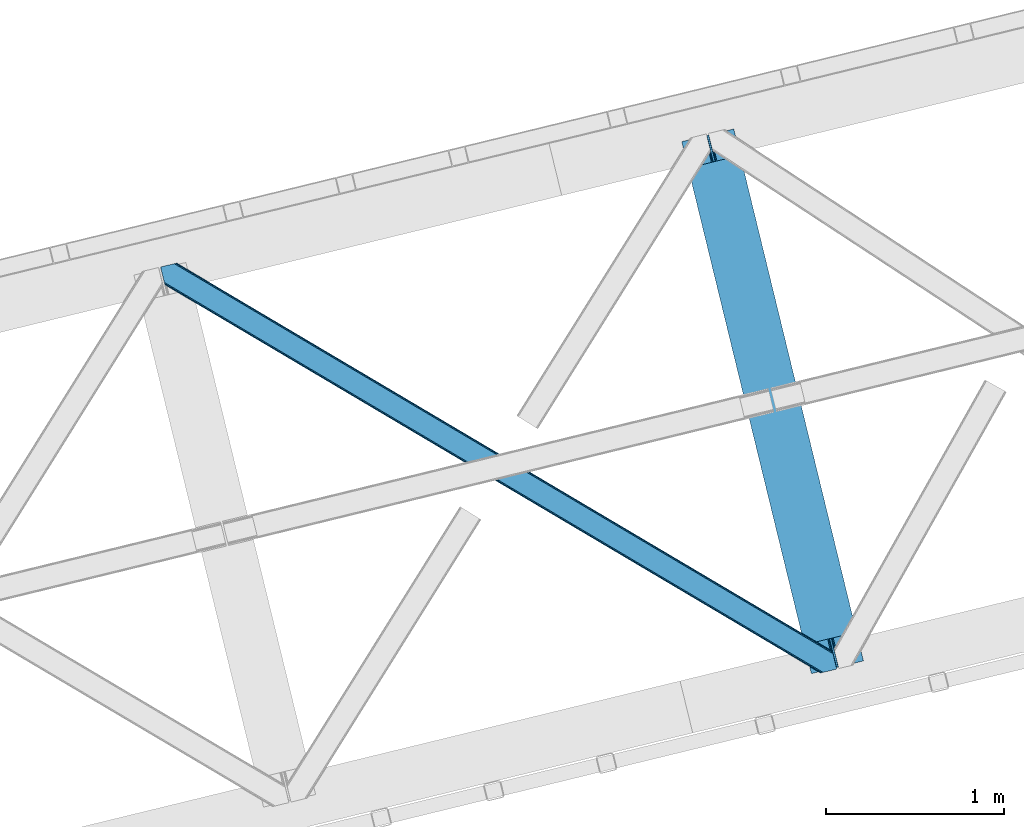
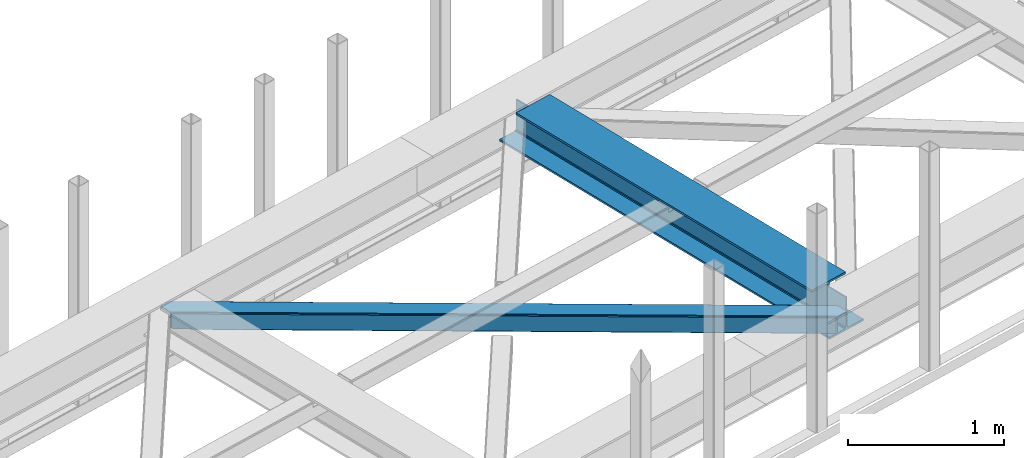
# One storey, part 52 of 66: 1 beam, 1 member.
"""IFC4 building model written with IfcOpenShell, lengths in millimetres."""

import ifcopenshell
import ifcopenshell.guid

model = None  # the IFC model being written
_history = None  # IfcOwnerHistory: only IFC2X3 demands one
_inside = {}  # id of a spatial element -> (the spatial element, [elements in it])
_under = {}  # id of a project, library or spatial element -> (it, [spatial elements below it])
_declared = {}  # id of a project -> (the project, [libraries it declares])
_typed = {}  # id of a type object -> (the type object, [elements of that type])
_made_of = {}  # id of a material, layer set ... -> (it, [elements and type objects made of it])


def new_model(schema):
    """Start an empty IFC model of exactly this schema.

    Asked for "IFC4X3", IfcOpenShell would pick the latest addendum, in which some entities
    have other attributes; the version numbers below select the first issue.
    IFC2X3 requires an IfcOwnerHistory on every rooted entity: one is made here for all.
    """
    global model, _history
    if schema == "IFC4X3":
        model = ifcopenshell.file(schema_version=(4, 3, 0, 0))
    else:
        model = ifcopenshell.file(schema=schema)
    _inside.clear()
    _under.clear()
    _declared.clear()
    _typed.clear()
    _made_of.clear()
    _history = None
    if model.schema == "IFC2X3":
        org = make("IfcOrganization", Name="unknown")
        user = make(
            "IfcPersonAndOrganization",
            ThePerson=make("IfcPerson", FamilyName="unknown"),
            TheOrganization=org,
        )
        app = make(
            "IfcApplication",
            ApplicationDeveloper=org,
            Version="unknown",
            ApplicationFullName="unknown",
            ApplicationIdentifier="unknown",
        )
        _history = make(
            "IfcOwnerHistory",
            OwningUser=user,
            OwningApplication=app,
            ChangeAction="ADDED",
            CreationDate=0,
        )
    return model


def make(cls, **values):
    """One entity of the class cls with the attributes given. An attribute that is None is left unset."""
    return model.create_entity(
        cls, **{name: value for name, value in values.items() if value is not None}
    )


def entity(cls, *values):
    """Any entity or typed value of the class cls, its attributes in the order of the schema. None: left unset."""
    e = model.create_entity(cls)
    for i, value in enumerate(values):
        if value is not None:
            e[i] = value
    return e


def rooted(cls, **values):
    """An entity with a GlobalId (a new one), such as an element, a storey or a relation."""
    return make(cls, GlobalId=ifcopenshell.guid.new(), OwnerHistory=_history, **values)


def si_unit(unit_type, name, prefix=None):
    """IfcSIUnit, for example si_unit("LENGTHUNIT", "METRE", prefix="MILLI")."""
    return make("IfcSIUnit", UnitType=unit_type, Prefix=prefix, Name=name)


def converted_unit(unit_type, name, factor, base, dimensions=None, offset=None):
    """IfcConversionBasedUnit, such as the inch: factor (a typed value) times the base unit."""
    return make(
        "IfcConversionBasedUnit"
        if offset is None
        else "IfcConversionBasedUnitWithOffset",
        ConversionOffset=offset,
        Dimensions=None
        if dimensions is None
        else entity("IfcDimensionalExponents", *dimensions),
        UnitType=unit_type,
        Name=name,
        ConversionFactor=make(
            "IfcMeasureWithUnit", ValueComponent=factor, UnitComponent=base
        ),
    )


def derived_unit(unit_type, elements):
    """IfcDerivedUnit: a product of units, each with its exponent."""
    return make(
        "IfcDerivedUnit",
        Elements=[
            make("IfcDerivedUnitElement", Unit=unit, Exponent=power)
            for unit, power in elements
        ],
        UnitType=unit_type,
    )


def assignment(units):
    """IfcUnitAssignment: the units of a project."""
    return None if units is None else make("IfcUnitAssignment", Units=units)


def point(xyz):
    """IfcCartesianPoint."""
    return None if xyz is None else make("IfcCartesianPoint", Coordinates=xyz)


def direction(xyz):
    """IfcDirection."""
    return None if xyz is None else make("IfcDirection", DirectionRatios=xyz)


def frame(location, z_axis=None, x_axis=None):
    """IfcAxis2Placement3D, a coordinate frame: its origin and axes. An axis left out is left unset."""
    return make(
        "IfcAxis2Placement3D",
        Location=point(location),
        Axis=direction(z_axis),
        RefDirection=direction(x_axis),
    )


def origin():
    """The frame at (0, 0, 0) with its axes left unset."""
    return frame((0.0, 0.0, 0.0))


def place(relative_to, where):
    """IfcLocalPlacement: puts the frame where relative to a parent placement (None: the world)."""
    return make(
        "IfcLocalPlacement", PlacementRelTo=relative_to, RelativePlacement=where
    )


def context(
    kind, dimensions, precision=None, world=None, true_north=None, identifier=None
):
    """IfcGeometricRepresentationContext, for example the 3D "Model" context."""
    return make(
        "IfcGeometricRepresentationContext",
        ContextIdentifier=identifier,
        ContextType=kind,
        CoordinateSpaceDimension=dimensions,
        Precision=precision,
        WorldCoordinateSystem=world,
        TrueNorth=true_north,
    )


def subcontext(parent, identifier, kind, view, scale=None):
    """IfcGeometricRepresentationSubContext, for example "Body" below "Model"."""
    return make(
        "IfcGeometricRepresentationSubContext",
        ContextIdentifier=identifier,
        ContextType=kind,
        ParentContext=parent,
        TargetScale=scale,
        TargetView=view,
    )


def project(units=None, contexts=None):
    """IfcProject with its units and contexts."""
    return rooted(
        "IfcProject",
        Name="project",
        RepresentationContexts=contexts,
        UnitsInContext=assignment(units),
    )


def spatial(cls, under=None, at=None, **own):
    """A site, building, storey or space (cls), placed at a placement, below another one or the project."""
    s = rooted(cls, ObjectPlacement=at, **own)
    if under is not None:
        _under.setdefault(under.id(), (under, []))[1].append(s)
    return s


def point_list(points):
    """IfcCartesianPointList2D or 3D."""
    cls = (
        "IfcCartesianPointList2D" if len(points[0]) == 2 else "IfcCartesianPointList3D"
    )
    return make(cls, CoordList=points)


def triangles(points, corners, closed=None, point_numbers=None):
    """IfcTriangulatedFaceSet: each triangle names its three corners, points numbered from 1."""
    return make(
        "IfcTriangulatedFaceSet",
        Coordinates=point_list(points),
        Closed=closed,
        CoordIndex=corners,
        PnIndex=point_numbers,
    )


def polygons(points, faces, closed=None, point_numbers=None):
    """IfcPolygonalFaceSet: a face is its outer loop, then its inner loops; points numbered from 1."""
    made = []
    for loops in faces:
        if len(loops) == 1:
            made.append(make("IfcIndexedPolygonalFace", CoordIndex=loops[0]))
        else:
            made.append(
                make(
                    "IfcIndexedPolygonalFaceWithVoids",
                    CoordIndex=loops[0],
                    InnerCoordIndices=loops[1:],
                )
            )
    return make(
        "IfcPolygonalFaceSet",
        Coordinates=point_list(points),
        Closed=closed,
        Faces=made,
        PnIndex=point_numbers,
    )


def shape(context_of_items, identifier, shape_type, items):
    """IfcShapeRepresentation: the items that make up one representation, for example the "Body"."""
    return make(
        "IfcShapeRepresentation",
        ContextOfItems=context_of_items,
        RepresentationIdentifier=identifier,
        RepresentationType=shape_type,
        Items=items,
    )


def material(Name=None, Category=None):
    """IfcMaterial."""
    return make("IfcMaterial", Name=Name, Category=Category)


def made_of(thing, what):
    """Note that an element or type object is made of a material, layer set ...; save() writes the relation."""
    if what is not None:
        _made_of.setdefault(what.id(), (what, []))[1].append(thing)
    return thing


def type_object(cls, material=None, **own):
    """A type object (cls), such as IfcWallType, which elements share."""
    return made_of(rooted(cls, **own), material)


def element(
    cls,
    number,
    at=None,
    inside=None,
    cuts=None,
    type_object=None,
    material=None,
    context=None,
    identifier="Body",
    shape_type=None,
    held_by="IfcProductDefinitionShape",
    body=None,
    shapes=None,
    **own,
):
    """One element of the class cls, such as IfcWall. Its Tag is "e" and its number.

    at: its placement. inside: the storey or other place that contains it. cuts: it is an
    opening in that element (IfcRelVoidsElement). A single representation is given by context,
    identifier, shape_type and body (its items); several are given by shapes. held_by: the class
    of the entity that holds the representations. save() writes the other relations.
    """
    e = rooted(cls, Tag="e%d" % number, ObjectPlacement=at, **own)
    if body is not None:
        shapes = [shape(context, identifier, shape_type, body)]
    if shapes is not None:
        e.Representation = make(held_by, Representations=shapes)
    if inside is not None:
        _inside.setdefault(inside.id(), (inside, []))[1].append(e)
    if cuts is not None:
        rooted(
            "IfcRelVoidsElement", RelatingBuildingElement=cuts, RelatedOpeningElement=e
        )
    if type_object is not None:
        _typed.setdefault(type_object.id(), (type_object, []))[1].append(e)
    return made_of(e, material)


def aggregate(whole, parts):
    """IfcRelAggregates: a whole, such as a stair, and the parts it consists of."""
    return rooted("IfcRelAggregates", RelatingObject=whole, RelatedObjects=parts)


def save(model, path):
    """Write the relations noted so far, then the file.

    IfcRelAggregates (storeys below a building ...), IfcRelContainedInSpatialStructure (elements
    in a storey), IfcRelDefinesByType, IfcRelAssociatesMaterial and IfcRelDeclares: one each for
    every whole, place, type object, material and project.
    """
    for whole, parts in _under.values():
        aggregate(whole, parts)
    for where, things in _inside.values():
        rooted(
            "IfcRelContainedInSpatialStructure",
            RelatedElements=things,
            RelatingStructure=where,
        )
    for kind, things in _typed.values():
        rooted("IfcRelDefinesByType", RelatedObjects=things, RelatingType=kind)
    for what, things in _made_of.values():
        rooted("IfcRelAssociatesMaterial", RelatedObjects=things, RelatingMaterial=what)
    for by, libraries in _declared.values():
        rooted("IfcRelDeclares", RelatingContext=by, RelatedDefinitions=libraries)
    model.write(path)


model = new_model("IFC4")

# Units and contexts
model_context = context("Model", 3, precision=0.01, world=origin(), true_north=direction((6.12303176911189e-17, 1.0)))
plan_context = context("Plan", 3, precision=0.01, world=origin(), true_north=direction((6.12303176911189e-17, 1.0)))
body_context = subcontext(model_context, "Body", "Model", "MODEL_VIEW")
ifc_project = project(units=[si_unit("LENGTHUNIT", "METRE", prefix="MILLI"), si_unit("AREAUNIT", "SQUARE_METRE"), si_unit("VOLUMEUNIT", "CUBIC_METRE"), converted_unit("PLANEANGLEUNIT", "DEGREE", entity("IfcRatioMeasure", 0.0174532925199433), si_unit("PLANEANGLEUNIT", "RADIAN"), dimensions=[0, 0, 0, 0, 0, 0, 0]), si_unit("MASSUNIT", "GRAM", prefix="KILO"), derived_unit("MASSDENSITYUNIT", [(si_unit("MASSUNIT", "GRAM", prefix="KILO"), 1), (si_unit("LENGTHUNIT", "METRE"), -3)]), derived_unit("MOMENTOFINERTIAUNIT", [(si_unit("LENGTHUNIT", "METRE"), 4)]), si_unit("TIMEUNIT", "SECOND"), si_unit("FREQUENCYUNIT", "HERTZ"), si_unit("THERMODYNAMICTEMPERATUREUNIT", "DEGREE_CELSIUS"), derived_unit("THERMALTRANSMITTANCEUNIT", [(si_unit("MASSUNIT", "GRAM", prefix="KILO"), 1), (si_unit("THERMODYNAMICTEMPERATUREUNIT", "KELVIN"), -1), (si_unit("TIMEUNIT", "SECOND"), -3)]), derived_unit("VOLUMETRICFLOWRATEUNIT", [(si_unit("LENGTHUNIT", "METRE"), 3), (si_unit("TIMEUNIT", "SECOND"), -1)]), derived_unit("MASSFLOWRATEUNIT", [(si_unit("MASSUNIT", "GRAM", prefix="KILO"), 1), (si_unit("TIMEUNIT", "SECOND"), -1)]), derived_unit("ROTATIONALFREQUENCYUNIT", [(si_unit("TIMEUNIT", "SECOND"), -1)]), si_unit("ELECTRICCURRENTUNIT", "AMPERE"), si_unit("ELECTRICVOLTAGEUNIT", "VOLT"), si_unit("POWERUNIT", "WATT"), si_unit("FORCEUNIT", "NEWTON", prefix="KILO"), si_unit("ILLUMINANCEUNIT", "LUX"), si_unit("LUMINOUSFLUXUNIT", "LUMEN"), si_unit("LUMINOUSINTENSITYUNIT", "CANDELA"), derived_unit("USERDEFINED", [(si_unit("MASSUNIT", "GRAM", prefix="KILO"), -1), (si_unit("LENGTHUNIT", "METRE"), -2), (si_unit("TIMEUNIT", "SECOND"), 3), (si_unit("LUMINOUSFLUXUNIT", "LUMEN"), 1)]), derived_unit("LINEARVELOCITYUNIT", [(si_unit("LENGTHUNIT", "METRE"), 1), (si_unit("TIMEUNIT", "SECOND"), -1)]), si_unit("PRESSUREUNIT", "PASCAL"), derived_unit("USERDEFINED", [(si_unit("LENGTHUNIT", "METRE"), -2), (si_unit("MASSUNIT", "GRAM", prefix="KILO"), 1), (si_unit("TIMEUNIT", "SECOND"), -2)]), derived_unit("LINEARFORCEUNIT", [(si_unit("MASSUNIT", "GRAM", prefix="KILO"), 1), (si_unit("LENGTHUNIT", "METRE"), 1), (si_unit("TIMEUNIT", "SECOND"), -2), (si_unit("LENGTHUNIT", "METRE"), -1)]), derived_unit("PLANARFORCEUNIT", [(si_unit("MASSUNIT", "GRAM", prefix="KILO"), 1), (si_unit("LENGTHUNIT", "METRE"), 1), (si_unit("TIMEUNIT", "SECOND"), -2), (si_unit("LENGTHUNIT", "METRE"), -2)])], contexts=[model_context, plan_context])

# Site, building, storey
site_placement = place(None, origin())
site = spatial("IfcSite", under=ifc_project, at=site_placement, CompositionType="ELEMENT")
building_placement = place(site_placement, origin())
building = spatial("IfcBuilding", under=site, at=building_placement, CompositionType="ELEMENT")
storey_placement = place(building_placement, frame((0.0, 0.0, 19800.0)))
storey = spatial("IfcBuildingStorey", under=building, at=storey_placement, Name="06", CompositionType="ELEMENT", Elevation=19800.0)

# Beam
ifc_material = material(Name="Metal painted (White)")
beam_type = type_object("IfcBeamType", PredefinedType="BEAM")
beam_placement = place(storey_placement, frame((-11884.4, 14897.98, 3807.02)))
element("IfcBeam", 1, at=beam_placement, inside=storey, type_object=beam_type, material=ifc_material, ObjectType="Steel Beam", PredefinedType="BEAM", context=body_context, shape_type="Tessellation", body=[
    polygons([(1018.1664837833, 71.0478278971021, 15.5000000000008), (1018.1664837833, 71.0478278971021, 0.0), (291.465617442446, 3052.25531830421, 0.0), (291.465617442448, 3052.25531830421, 15.5000000000008), (894.779372399325, 40.970914087327, 15.5000000000008), (168.078506058474, 3022.17840449444, 15.5000000000008), (888.087028625373, 39.3395844888265, 16.8701684147984), (161.386162284522, 3020.54707489594, 16.8701684147984), (882.413533524757, 37.956610033654, 20.7720779386434), (155.712667183906, 3019.16410044077, 20.7720779386434), (878.622625296178, 37.0325360459184, 26.6116982174294), (151.921758955329, 3018.24002645303, 26.6116982174294), (877.291435352781, 36.7080444135029, 33.500000000001), (150.59056901193, 3017.91553482062, 33.500000000001), (140.875048430516, 3015.54727389071, 33.500000000001), (140.875048430518, 3015.54727389072, 259.000000000002), (150.590569011926, 3017.91553482062, 259.000000000002), (0.0, 2981.20749040711, 0.0), (0.0, 2981.20749040711, 15.4999999999965), (123.387111383964, 3011.28440421689, 15.5000000000008), (130.079455157922, 3012.91573381539, 16.8701684147984), (135.75295025854, 3014.29870827056, 20.7720779386434), (139.543858487119, 3015.2227822583, 26.6116982174294), (877.291435352779, 36.7080444135029, 259.000000000002), (867.575914771371, 34.3397834836014, 259.000000000002), (867.575914771369, 34.3397834836014, 33.500000000001), (866.24472482797, 34.0152918511859, 26.6116982174294), (862.453816599391, 33.0912178634502, 20.7720779386434), (856.780321498773, 31.70824340828, 16.8701684147984), (850.087977724817, 30.0769138097752, 15.5000000000008), (726.700866340853, 0.0, 15.4999999999965), (726.700866340851, 0.0, 0.0), (838.124523615903, 197.385937999177, 259.069791973884), (186.469722099962, 2870.72539801219, 259.000000000002), (186.693115201814, 2869.8089536072, 259.617303331124), (186.705504045441, 2869.75812937344, 266.500003008253), (837.979344808139, 197.981416001702, 266.500002998871), (837.979694928891, 197.97997969697, 260.000004007589), (828.499586345885, 194.645865944436, 259.006343171919), (828.276216326122, 195.562317481916, 259.617303331124), (828.263827482494, 195.613141715691, 266.500003008253), (176.989986719795, 2867.38985508742, 266.500002998871), (176.989636599043, 2867.39129139216, 260.000004007589), (176.844830940709, 2867.98534020595, 259.07612046749), (176.754201518552, 2868.35713708228, 259.000000000002), (839.310832678068, 198.30468544639, 273.388305639783), (843.101109266764, 199.231350618303, 279.227924098781), (848.774180214298, 200.616065081983, 283.129832400619), (855.466371895423, 202.248018612794, 284.500000377224), (978.853400583271, 232.325271667905, 284.500000138971), (978.85173077662, 232.332121736639, 299.999995328161), (687.386308679347, 161.283492472596, 299.999995890962), (687.387978485999, 161.276642403863, 284.500000701776), (810.775007173843, 191.353895458974, 284.500000463519), (817.467494069984, 192.984637925553, 283.129832461069), (823.141405718746, 194.365903570079, 279.227924137322), (826.93294050574, 195.287407219375, 273.388305663684), (175.658498849859, 2867.06658564273, 273.388305639783), (171.868222261163, 2866.13992047082, 279.227924098781), (166.195151313627, 2864.75520600715, 283.129832400619), (159.502959632495, 2863.12325247633, 284.500000377228), (36.1159309446555, 2833.04599942122, 284.500000138971), (36.117600751305, 2833.03914935249, 299.999995328161), (327.583022848578, 2904.08777861653, 299.999995890962), (327.58135304193, 2904.09462868526, 284.500000701776), (204.194324354075, 2874.01737563015, 284.500000463519), (197.501837457941, 2872.38663316357, 283.129832461069), (191.827925809183, 2871.00536751905, 279.227924137322), (188.036391022187, 2870.08386386975, 273.388305663684)], [[[1, 2, 3, 4]], [[5, 1, 4, 6]], [[7, 5, 6, 8]], [[9, 7, 8, 10]], [[11, 9, 10, 12]], [[13, 11, 12, 14]], [[15, 16, 17, 14, 12, 10, 8, 6, 4, 3, 18, 19, 20, 21, 22, 23]], [[13, 24, 25, 26, 27, 28, 29, 30, 31, 32, 2, 1, 5, 7, 9, 11]], [[2, 32, 18, 3]], [[32, 31, 19, 18]], [[31, 30, 20, 19]], [[27, 26, 15, 23]], [[28, 27, 23, 22]], [[29, 28, 22, 21]], [[30, 29, 21, 20]], [[33, 24, 13, 14, 17, 34, 35, 36, 37, 38]], [[25, 39, 40, 41, 42, 43, 44, 16, 15, 26]], [[39, 25, 24, 33]], [[45, 34, 17, 16]], [[41, 40, 38, 37, 46, 47, 48, 49, 50, 51, 52, 53, 54, 55, 56, 57]], [[42, 58, 59, 60, 61, 62, 63, 64, 65, 66, 67, 68, 69, 36, 35, 43]], [[46, 37, 36, 69]], [[47, 46, 69, 68]], [[48, 47, 68, 67]], [[49, 48, 67, 66]], [[50, 49, 66, 65]], [[51, 50, 65, 64]], [[52, 51, 64, 63]], [[53, 52, 63, 62]], [[54, 53, 62, 61]], [[55, 54, 61, 60]], [[56, 55, 60, 59]], [[57, 56, 59, 58]], [[41, 57, 58, 42]]], closed=False),
])

# Member
member_type = type_object("IfcMemberType", PredefinedType="BRACE")
member_placement = place(storey_placement, frame((-14805.08, 14901.03, 3823.0)))
element("IfcMember", 2, at=member_placement, inside=storey, type_object=member_type, ObjectType="Steel Horizontal Brace", PredefinedType="BRACE", context=body_context, shape_type="Tessellation", body=[
    triangles([(3167.12877502441, 476.931353759765, 17.5012573242202), (3764.84694213867, 123.064581298828, 122.499499511719), (3764.84694213867, 123.064581298828, 17.5012573242202), (2547.33637390137, 843.862445068358, 17.5012573242202), (1927.54397277832, 1210.79469909668, 17.5012573242202), (91.5002288818359, 2297.77602539062, 122.499499511719), (687.959170532227, 1944.65920715332, 17.5012573242202), (91.5002288818359, 2297.77602539062, 17.5012573242202), (1307.75157165527, 1577.726953125, 17.5012573242202), (3770.63961181641, 99.2985900878903, 140.00075683594), (3768.42230529785, 108.393383789062, 138.668280029298), (76.4813781738285, 2294.11462097168, 138.668280029298), (67.1679931640629, 2291.8438293457, 140.00075683594), (3766.54335021973, 116.103378295898, 134.87548828125), (84.3750823974606, 2296.03892211914, 134.87548828125), (3765.28761291504, 121.255389404296, 129.196765136719), (89.6480163574215, 2297.32372741699, 129.196765136719), (3722.23907775879, 5.93103332519422, 140.00075683594), (18.7674591064442, 2198.47743530274, 140.00075683594), (3789.40823364258, 22.304452514647, 140.00075683594), (0.0, 2275.47157287598, 140.00075683594), (3697.90684204101, 0.0, 122.499499511719), (3699.75905456543, 0.451135253904795, 129.196765136719), (24.1206207275391, 2176.5194732666, 129.196765136719), (24.5612915039055, 2174.7114440918, 122.499499511719), (3705.0366394043, 1.73826599121094, 134.87548828125), (22.8637207031243, 2181.671484375, 134.87548828125), (3712.93150634766, 3.66256713867188, 138.668280029298), (20.9847656250004, 2189.38264160156, 138.668280029298), (1862.08168945313, 1086.85342712402, 17.5012573242202), (2481.94036560059, 719.882803344726, 17.5012573242202), (3101.79555358887, 352.912179565428, 17.5012573242202), (3697.90684204101, 0.0, 17.5012573242202), (1242.22650146484, 1453.82405090332, 17.5012573242202), (622.367825317382, 1820.79467468262, 17.5012573242202), (24.5612915039055, 2174.7114440918, 17.5012573242202), (74.6419555664052, 2293.66581115723, 127.873590087893), (66.7482513427731, 2291.74151000976, 131.668707275392), (79.9148895263661, 2294.9517791748, 122.197192382813), (57.4348663330074, 2289.47188110352, 133.001184082033), (0.0, 2275.47157287598, 133.001184082033), (81.7682647705078, 2295.40291442871, 115.499926757813), (81.7682647705078, 2295.40291442871, 24.5008300781265), (79.9148895263661, 2294.9517791748, 17.8035644531265), (89.5619750976566, 2297.30279846191, 10.8156188964858), (89.4724456787098, 2297.28070678711, 10.4993591308594), (74.1129180908192, 2293.53674926758, 12.4271484375022), (72.0351379394524, 2293.03096618652, 10.4993591308594), (1922.19197387695, 1205.8275604248, 24.5008300781265), (3767.16424255371, 113.558184814452, 115.499926757813), (2545.11092834473, 837.046582031249, 24.5008300781265), (3168.02523193359, 468.263278198241, 24.5008300781265), (3767.16424255371, 113.558184814452, 24.5008300781265), (1299.27650756836, 1574.60970153808, 24.5008300781265), (676.357553100586, 1943.39067993164, 24.5008300781265), (3767.60491333008, 111.748992919922, 122.197192382813), (3768.86065063477, 106.596981811523, 127.873590087893), (3770.73960571289, 98.886987304686, 131.668707275392), (3772.95691223145, 89.7910308837891, 133.001184082033), (3767.6932800293, 111.385061645507, 17.8686767578147), (3767.80141296387, 110.943228149414, 16.5199218750022), (3764.85508117676, 123.027374267578, 16.5199218750022), (3789.40823364258, 22.304452514647, 133.001184082033), (3731.97220458984, 8.30414428710901, 133.001184082033), (16.4501586914066, 2207.98383178711, 133.001184082033), (162.73657836914, 2253.90428466797, 10.4993591308594), (166.887487792968, 2236.87509155273, 10.4993591308594), (3722.66463317871, 6.03451538085938, 131.668707275392), (18.6674652099609, 2198.88903808594, 131.668707275392), (3714.76976623535, 4.11021423339844, 127.873590087893), (20.5464202880848, 2191.1790435791, 127.873590087893), (3709.49218139648, 2.82424621581958, 122.197192382813), (21.8033203124996, 2186.0270324707, 122.197192382813), (3707.63996887207, 2.3719482421875, 115.499926757813), (22.2439910888661, 2184.21784057617, 115.499926757813), (3114.18549499512, 353.713293457031, 24.5008300781265), (3707.63996887207, 2.3719482421875, 24.5008300781265), (2491.1200378418, 722.583801269531, 24.5008300781265), (1868.05458068848, 1091.45547180176, 24.5008300781265), (621.91901550293, 1829.19532470703, 24.5008300781265), (22.2439910888661, 2184.21784057617, 24.5008300781265), (1244.98447265625, 1460.32481689453, 24.5008300781265), (3709.49218139648, 2.82424621581958, 17.8035644531265), (3700.13461303711, 0.542990112304324, 10.8691040039084), (3700.58691101074, 0.653448486327761, 9.52034912109593), (3714.76976623535, 4.11021423339844, 12.1248413085959), (3719.39273986816, 5.23688964843677, 9.52034912109593), (21.7823913574211, 2186.11191101074, 17.817517089843), (21.7602996826172, 2186.20144042969, 17.5012573242202), (32.138735961913, 2171.84766540527, 10.8179443359368), (28.3459442138665, 2188.73965759277, 10.4993591308594), (27.0134674072269, 2187.35253295898, 12.1248413085959), (32.4968536376946, 2171.71046447754, 10.4993591308594), (203.965457153321, 2084.76809692383, 10.4993591308594), (208.116366577149, 2067.74006652832, 10.4993591308594), (164.096960449218, 2252.54739074707, 9.49942016601563), (168.582733154297, 2234.14502563476, 9.49942016601563), (168.16531677246, 2234.81824035645, 9.74591674804833), (163.767910766601, 2252.87527770996, 9.74126586914281), (167.737435913086, 2235.51122131347, 9.9993896484375), (163.419094848632, 2253.22641906738, 9.9993896484375), (167.304904174804, 2236.20303955078, 10.2528625488303), (163.065628051758, 2253.5775604248, 10.2598388671868), (209.161651611328, 2067.67146606445, 9.49942016601563), (209.134909057617, 2067.46682739258, 9.88311767578125), (204.681692504882, 2085.44363708496, 9.8528869628899), (208.802371215821, 2067.55635681152, 10.0831054687515), (204.68285522461, 2084.81111755371, 10.2063537597678), (208.448904418945, 2067.65053710937, 10.2993713378928), (204.323574829101, 2084.79018859863, 10.3528564453118), (204.67587890625, 2086.07499389648, 9.49942016601563), (3763.57841491699, 109.727023315429, 12.1248413085959), (3758.57058105469, 124.97144165039, 10.8714294433594), (3757.06369628906, 125.435366821288, 9.52034912109593), (3761.54249267578, 107.063232421875, 9.52034912109593), (3585.92297973633, 211.034793090819, 9.52034912109593), (3581.44418334961, 229.405764770507, 9.52034912109593), (3585.50556335449, 211.134786987304, 9.44360961914208), (3581.0453704834, 229.55343017578, 9.37384643554833), (3580.64539489746, 229.701095581055, 9.22734375000073), (3580.53726196289, 229.533663940429, 8.87387695312646), (3585.45556640625, 210.476687622069, 9.13897705078125), (3580.42564086914, 229.365069580077, 8.52041015625218), (3585.40440673828, 209.805798339843, 8.82736816406396), (3585.35324707031, 209.147698974608, 8.52041015625218), (3164.51730651856, 472.519995117187, 5.12526855468968), (3581.30116882324, 225.771102905273, 5.12526855468968), (3166.45090942383, 475.784912109375, 10.8039916992202), (687.281304931641, 1943.51276550293, 10.8039916992202), (685.347702026367, 1940.24784851074, 5.12526855468968), (165.152709960938, 2248.21625976562, 5.12526855468968), (682.454855346679, 1935.36326293945, 1.33247680664135), (167.031665039061, 2240.50510253906, 1.33247680664135), (679.044598388671, 1929.59966125488, 0.0), (169.248971557618, 2231.41030883789, 0.0), (3583.18128662109, 218.061108398437, 1.33247680664135), (3585.39743041992, 208.966314697265, 0.0), (3158.21420288086, 461.871807861327, 0.0), (3161.62562255859, 467.635409545897, 1.33247680664135), (2546.65850830078, 842.717166137694, 10.8039916992202), (1926.86610717774, 1209.64825744629, 10.8039916992202), (1307.07370605469, 1576.58051147461, 10.8039916992202), (2544.72490539551, 839.452249145506, 5.12526855468968), (1924.93250427246, 1206.38450317383, 5.12526855468968), (1305.14010314941, 1573.31675720215, 5.12526855468968), (2541.83322143555, 834.566500854491, 1.33247680664135), (1922.0408203125, 1201.49875488281, 1.33247680664135), (1302.24841918945, 1568.43100891113, 1.33247680664135), (2538.42180175781, 828.804061889648, 0.0), (1918.62940063477, 1195.73631591797, 0.0), (1298.83699951172, 1562.66856994629, 0.0), (3620.15809936524, 66.3657165527329, 0.0), (3110.71477661133, 367.971725463867, 0.0), (2490.85493774414, 734.942349243163, 0.0), (1870.99626159668, 1101.91181030273, 0.0), (631.282397460938, 1835.85305786133, 0.0), (1251.1410736084, 1468.88359680176, 0.0), (204.009640502929, 2088.80971069336, 0.0), (3167.34736633301, 467.117999267577, 17.8035644531265), (3165.41492614746, 463.853082275389, 12.1248413085959), (673.747247314453, 1938.98048400879, 12.1248413085959), (675.6796875, 1942.24540100098, 17.8035644531265), (670.854400634766, 1934.09473571777, 8.3320495605476), (169.397799682616, 2230.8022064209, 8.81806640624927), (171.566271972655, 2221.90391235351, 6.99957275390625), (3159.11065979004, 453.204895019531, 6.99957275390625), (3587.71589355469, 199.458755493164, 6.99957275390625), (3585.50556335449, 208.524481201172, 8.42274169921802), (3162.52207946777, 458.967333984374, 8.3320495605476), (667.442980957032, 1928.33229675293, 6.99957275390625), (2536.19635620117, 821.987036132812, 6.99957275390625), (2539.60777587891, 827.749475097655, 8.3320495605476), (1913.2774017334, 1190.76917724609, 6.99957275390625), (1916.68765869141, 1196.53161621094, 8.3320495605476), (1290.3619354248, 1559.55131835938, 6.99957275390625), (1293.77335510254, 1565.31375732422, 8.3320495605476), (2542.49945983887, 832.635223388672, 12.1248413085959), (1919.58050537109, 1201.41620178223, 12.1248413085959), (1296.66620178223, 1570.19950561523, 12.1248413085959), (2544.43306274414, 835.900140380858, 17.8035644531265), (1921.51410827637, 1204.68111877441, 17.8035644531265), (1298.59864196777, 1573.4632598877, 17.8035644531265), (201.692340087891, 2098.31610717773, 6.99957275390625), (203.86081237793, 2089.41781311035, 8.81806640624927), (206.226947021485, 2079.71491699219, 1.33247680664135), (208.105902099609, 2072.00492248535, 5.12526855468968), (2500.03460998535, 737.642184448241, 6.99957275390625), (3123.10006713867, 368.771676635741, 6.99957275390625), (1876.96915283203, 1106.51385498047, 6.99957275390625), (3617.8407989502, 75.8721130371086, 6.99957275390625), (630.833587646484, 1844.25487060547, 6.99957275390625), (1253.8990447998, 1475.38320007324, 6.99957275390625), (3119.68864746094, 363.009237670898, 8.3320495605476), (3620.56272583008, 65.041378784179, 8.90410766601781), (3620.20228271484, 66.183169555663, 8.52041015625218), (3116.79580078125, 358.123489379883, 12.1248413085959), (3621.05339355469, 64.3216552734375, 9.1087463378899), (3621.54754943848, 63.5914672851559, 9.31571044922021), (3622.03937988281, 62.8729064941399, 9.52034912109593), (3620.05112915039, 66.8075500488267, 8.42274169921802), (624.529321289063, 1833.60668334961, 12.1248413085959), (627.422167968751, 1838.49243164063, 8.3320495605476), (622.596881103516, 1830.34176635742, 17.8035644531265), (3114.8633605957, 354.858572387695, 17.8035644531265), (2491.79790344238, 723.730242919921, 17.8035644531265), (1868.73244628906, 1092.60075073242, 17.8035644531265), (1245.66233825684, 1461.47125854492, 17.8035644531265), (2493.73034362793, 726.993997192381, 12.1248413085959), (1870.66488647461, 1095.86566772461, 12.1248413085959), (1247.59477844238, 1464.73501281738, 12.1248413085959), (2496.62319030762, 731.879745483398, 8.3320495605476), (1873.5577331543, 1100.75141601562, 8.3320495605476), (1250.48762512207, 1469.6207611084, 8.3320495605476), (3102.47807006836, 354.05862121582, 10.8039916992202), (624.978131103515, 1825.20487060547, 5.12526855468968), (623.045690917968, 1821.94111633301, 10.8039916992202), (3626.5170135498, 44.5019348144524, 9.52034912109593), (3104.41051025391, 357.323538208007, 5.12526855468968), (3624.25436096191, 49.5597656249993, 5.12526855468968), (3625.13105163574, 45.9669616699211, 8.52041015625218), (3625.82635803223, 45.2344482421868, 9.02037963867406), (3622.37540588379, 57.2709228515614, 1.33247680664135), (3107.29870605469, 362.208123779295, 1.33247680664135), (627.870977783203, 1830.09061889648, 1.33247680664135), (2487.44468078613, 729.178747558593, 1.33247680664135), (1867.58484191895, 1096.14937133789, 1.33247680664135), (1247.73081665039, 1463.11999511719, 1.33247680664135), (2484.55183410645, 724.294161987304, 5.12526855468968), (1864.69199523926, 1091.26362304687, 5.12526855468968), (1244.8379699707, 1458.2354095459, 5.12526855468968), (2482.6193939209, 721.029244995116, 10.8039916992202), (1862.75955505371, 1087.99986877441, 10.8039916992202), (1242.90552978516, 1454.97049255371, 10.8039916992202)], [[1, 2, 3], [2, 1, 4], [2, 5, 6], [5, 2, 4], [7, 8, 6], [9, 6, 5], [6, 9, 7], [10, 11, 12], [12, 13, 10], [11, 14, 15], [15, 12, 11], [14, 16, 17], [17, 15, 14], [16, 2, 6], [6, 17, 16], [18, 10, 19], [18, 20, 10], [13, 19, 10], [21, 19, 13], [22, 23, 24], [24, 25, 22], [23, 26, 27], [27, 24, 23], [26, 28, 29], [29, 27, 26], [28, 18, 19], [19, 29, 28], [30, 22, 25], [22, 31, 32], [30, 31, 22], [32, 33, 22], [34, 25, 35], [25, 34, 30], [36, 35, 25], [37, 38, 12], [15, 37, 12], [15, 17, 39], [37, 15, 39], [39, 17, 6], [38, 13, 12], [21, 40, 41], [21, 13, 40], [38, 40, 13], [39, 6, 42], [43, 8, 44], [6, 43, 42], [8, 45, 44], [6, 8, 43], [46, 44, 45], [46, 47, 44], [46, 48, 47], [49, 50, 42], [50, 51, 52], [49, 51, 50], [52, 53, 50], [54, 42, 55], [42, 54, 49], [43, 55, 42], [50, 56, 42], [39, 42, 56], [56, 57, 39], [37, 39, 57], [57, 58, 37], [38, 37, 58], [58, 59, 38], [40, 38, 59], [57, 14, 11], [59, 58, 10], [58, 57, 11], [60, 61, 62], [63, 59, 20], [10, 20, 59], [58, 11, 10], [60, 3, 53], [2, 50, 53], [53, 3, 2], [60, 62, 3], [2, 56, 50], [56, 14, 57], [14, 56, 16], [2, 16, 56], [59, 64, 65], [64, 59, 63], [65, 40, 59], [41, 40, 65], [66, 67, 46], [48, 46, 67], [64, 68, 65], [69, 65, 68], [68, 70, 69], [71, 69, 70], [70, 72, 71], [73, 71, 72], [72, 74, 73], [75, 73, 74], [76, 74, 77], [74, 76, 78], [74, 79, 75], [79, 74, 78], [80, 81, 75], [82, 75, 79], [75, 82, 80], [70, 68, 28], [26, 70, 28], [26, 23, 72], [70, 26, 72], [72, 23, 22], [68, 18, 28], [20, 64, 63], [20, 18, 64], [68, 64, 18], [72, 22, 74], [77, 33, 83], [22, 77, 74], [33, 84, 83], [22, 33, 77], [85, 83, 84], [86, 83, 85], [87, 86, 85], [73, 75, 25], [25, 24, 73], [27, 73, 24], [73, 27, 71], [25, 81, 36], [88, 89, 36], [36, 81, 88], [75, 81, 25], [69, 29, 19], [21, 65, 19], [41, 65, 21], [69, 71, 29], [29, 71, 27], [65, 69, 19], [90, 91, 92], [90, 93, 91], [92, 36, 90], [89, 36, 92], [94, 95, 93], [93, 91, 94], [96, 97, 98], [98, 99, 96], [99, 98, 100], [100, 101, 99], [101, 100, 102], [102, 103, 101], [103, 102, 67], [67, 66, 103], [104, 105, 106], [105, 107, 108], [108, 107, 109], [110, 109, 95], [95, 94, 110], [109, 110, 108], [108, 106, 105], [106, 111, 104], [62, 112, 113], [112, 62, 61], [112, 114, 113], [112, 115, 114], [114, 115, 116], [116, 117, 114], [118, 119, 117], [120, 119, 118], [121, 120, 122], [123, 121, 124], [124, 125, 123], [122, 124, 121], [118, 122, 120], [117, 116, 118], [1, 3, 113], [3, 62, 113], [120, 121, 126], [123, 126, 121], [123, 127, 126], [128, 113, 117], [117, 126, 128], [117, 119, 126], [120, 126, 119], [113, 114, 117], [45, 129, 66], [129, 130, 131], [131, 96, 129], [129, 99, 101], [99, 129, 96], [129, 103, 66], [103, 129, 101], [129, 45, 8], [8, 7, 129], [66, 46, 45], [130, 132, 133], [133, 131, 130], [132, 134, 135], [135, 133, 132], [136, 137, 138], [138, 139, 136], [127, 136, 139], [139, 126, 127], [113, 128, 1], [1, 128, 4], [140, 4, 128], [4, 140, 5], [141, 5, 140], [5, 141, 9], [142, 9, 141], [9, 142, 7], [129, 7, 142], [128, 126, 143], [143, 140, 128], [140, 143, 141], [144, 141, 143], [141, 144, 142], [145, 142, 144], [142, 145, 130], [130, 129, 142], [126, 139, 146], [146, 143, 126], [143, 146, 147], [147, 144, 143], [144, 147, 145], [148, 145, 147], [145, 148, 130], [132, 130, 148], [139, 138, 149], [149, 146, 139], [146, 149, 150], [150, 147, 146], [147, 150, 148], [151, 148, 150], [148, 151, 134], [134, 132, 148], [137, 152, 153], [138, 153, 154], [153, 138, 137], [149, 155, 150], [154, 149, 138], [149, 154, 155], [156, 134, 151], [150, 157, 151], [157, 150, 155], [157, 156, 151], [158, 134, 156], [135, 134, 158], [159, 160, 112], [112, 61, 159], [159, 60, 53], [161, 162, 44], [98, 163, 100], [98, 97, 163], [163, 102, 100], [163, 67, 102], [97, 164, 163], [161, 47, 67], [67, 163, 161], [47, 48, 67], [163, 164, 165], [166, 167, 168], [160, 118, 116], [116, 112, 160], [116, 115, 112], [169, 168, 125], [125, 160, 169], [124, 122, 160], [122, 118, 160], [160, 125, 124], [168, 169, 166], [165, 170, 163], [44, 47, 161], [162, 55, 43], [43, 44, 162], [53, 52, 159], [61, 60, 159], [166, 169, 171], [172, 171, 169], [171, 172, 173], [174, 173, 172], [173, 174, 175], [176, 175, 174], [175, 176, 163], [163, 170, 175], [169, 160, 177], [177, 172, 169], [172, 177, 178], [178, 174, 172], [174, 178, 179], [179, 176, 174], [176, 179, 163], [161, 163, 179], [160, 159, 177], [180, 177, 159], [177, 180, 181], [181, 178, 177], [178, 181, 182], [182, 179, 178], [179, 182, 162], [162, 161, 179], [159, 52, 180], [51, 180, 52], [180, 51, 181], [49, 181, 51], [181, 49, 182], [54, 182, 49], [182, 54, 162], [55, 162, 54], [97, 131, 133], [135, 97, 133], [165, 164, 135], [165, 135, 183], [131, 97, 96], [135, 164, 97], [183, 158, 184], [158, 185, 111], [158, 183, 135], [186, 111, 185], [158, 111, 184], [186, 104, 111], [187, 188, 166], [166, 171, 187], [171, 189, 187], [189, 171, 173], [188, 167, 166], [188, 190, 167], [170, 191, 175], [191, 170, 183], [165, 183, 170], [192, 175, 191], [173, 192, 189], [175, 192, 173], [193, 194, 195], [196, 197, 194], [196, 198, 197], [196, 199, 198], [194, 193, 196], [195, 200, 193], [86, 87, 199], [199, 196, 86], [193, 200, 190], [191, 183, 184], [201, 108, 110], [110, 94, 201], [94, 92, 201], [94, 91, 92], [202, 106, 108], [202, 111, 106], [202, 184, 111], [108, 201, 202], [203, 201, 92], [92, 89, 203], [203, 88, 81], [81, 80, 203], [89, 88, 203], [184, 202, 191], [190, 188, 193], [83, 86, 196], [196, 204, 83], [77, 83, 204], [204, 76, 77], [76, 204, 78], [205, 78, 204], [78, 205, 206], [206, 79, 78], [79, 206, 207], [207, 82, 79], [82, 207, 203], [203, 80, 82], [204, 196, 208], [208, 205, 204], [205, 208, 209], [209, 206, 205], [206, 209, 207], [210, 207, 209], [207, 210, 201], [201, 203, 207], [196, 193, 208], [211, 208, 193], [208, 211, 209], [212, 209, 211], [209, 212, 213], [213, 210, 209], [210, 213, 202], [202, 201, 210], [193, 188, 187], [187, 211, 193], [211, 187, 189], [189, 212, 211], [212, 189, 213], [192, 213, 189], [213, 192, 191], [191, 202, 213], [214, 84, 33], [35, 36, 90], [215, 105, 104], [216, 90, 95], [95, 215, 216], [95, 107, 215], [104, 186, 215], [84, 214, 217], [214, 218, 219], [219, 220, 214], [221, 217, 214], [214, 220, 221], [217, 85, 84], [222, 219, 218], [218, 223, 222], [152, 222, 223], [223, 153, 152], [156, 224, 185], [185, 158, 156], [224, 215, 186], [186, 185, 224], [90, 216, 35], [33, 32, 214], [153, 223, 225], [225, 154, 153], [154, 225, 226], [226, 155, 154], [155, 226, 227], [227, 157, 155], [157, 227, 224], [224, 156, 157], [223, 218, 225], [228, 225, 218], [225, 228, 226], [229, 226, 228], [226, 229, 227], [230, 227, 229], [227, 230, 224], [215, 224, 230], [218, 214, 228], [231, 228, 214], [228, 231, 232], [232, 229, 228], [229, 232, 230], [233, 230, 232], [230, 233, 216], [216, 215, 230], [214, 32, 31], [31, 231, 214], [231, 31, 30], [30, 232, 231], [232, 30, 233], [34, 233, 30], [233, 34, 216], [35, 216, 34], [137, 167, 190], [125, 127, 123], [137, 125, 167], [125, 136, 127], [125, 137, 136], [152, 137, 190], [195, 152, 190], [219, 195, 220], [195, 222, 152], [195, 219, 222], [220, 195, 194], [221, 194, 197], [221, 197, 198], [217, 198, 199], [87, 85, 199], [217, 199, 85]]),
])

save(model, "model.ifc")
